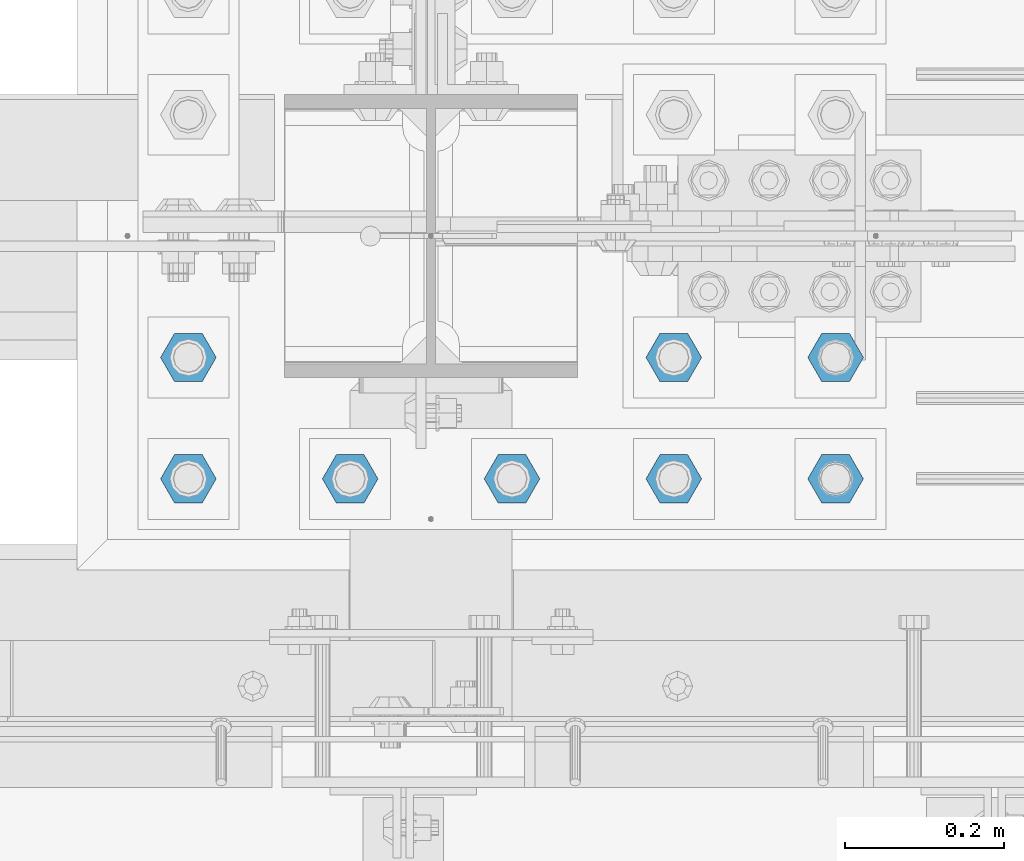
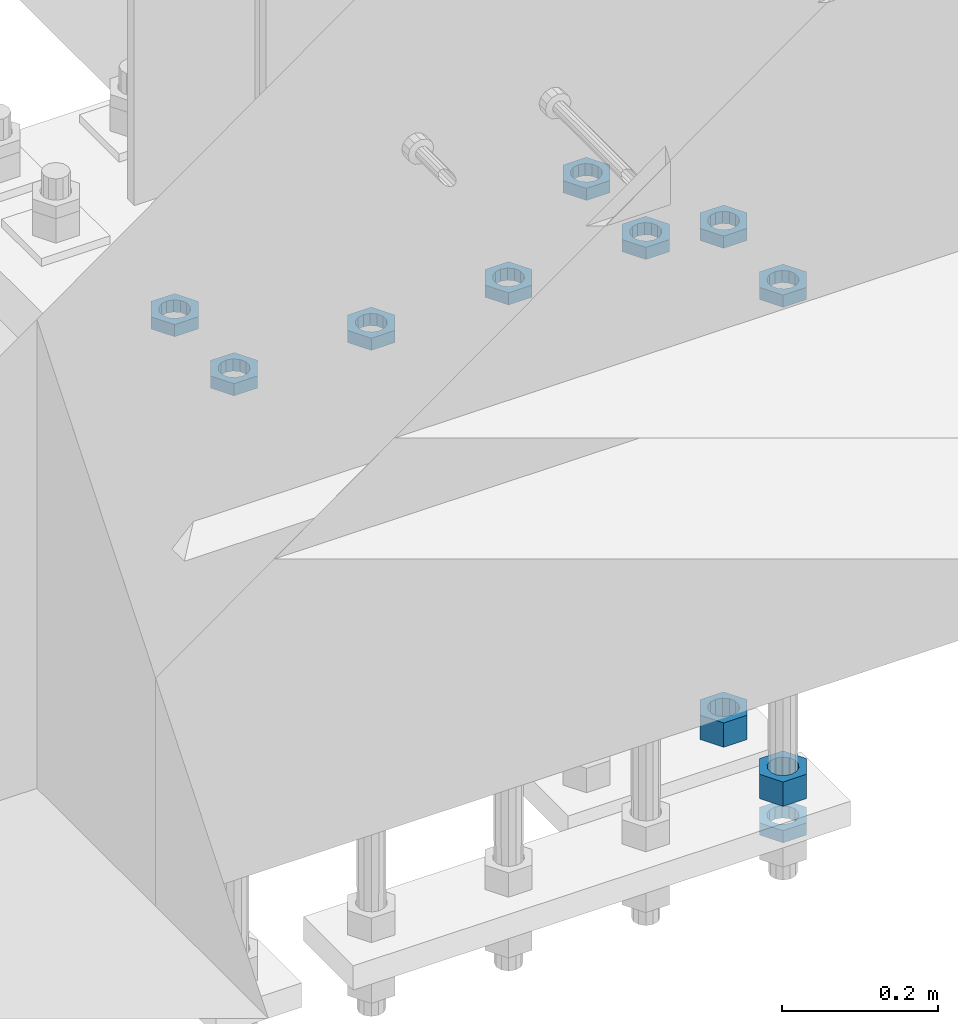
# One storey, part 2791 of 3843: 11 beams, 1 element without a shape of its own.
"""IFC2X3 building model written with IfcOpenShell, lengths in millimetres."""

from ifc_helpers import new_model, si_unit, frame, origin_with_axes, place, context, subcontext, project, spatial, faceted_brep, material, type_object, element, aggregate, save


model = new_model("IFC2X3")

# Units and contexts
model_context = context("Model", 3, precision=1e-05, world=origin_with_axes())
body_context = subcontext(model_context, "Body", "Model", "MODEL_VIEW")
ifc_project = project(units=[si_unit("LENGTHUNIT", "METRE", prefix="MILLI"), si_unit("AREAUNIT", "SQUARE_METRE"), si_unit("VOLUMEUNIT", "CUBIC_METRE"), si_unit("MASSUNIT", "GRAM", prefix="KILO"), si_unit("TIMEUNIT", "SECOND"), si_unit("PLANEANGLEUNIT", "RADIAN"), si_unit("SOLIDANGLEUNIT", "STERADIAN"), si_unit("THERMODYNAMICTEMPERATUREUNIT", "DEGREE_CELSIUS"), si_unit("LUMINOUSINTENSITYUNIT", "LUMEN")], contexts=[model_context])

# Site, building, storey
site_placement = place(None, origin_with_axes())
site = spatial("IfcSite", under=ifc_project, at=site_placement, CompositionType="ELEMENT")
building_placement = place(site_placement, origin_with_axes())
building = spatial("IfcBuilding", under=site, at=building_placement, Name="Undefined", CompositionType="ELEMENT")
storey_placement = place(building_placement, origin_with_axes())
storey = spatial("IfcBuildingStorey", under=building, at=storey_placement, Name="Undefined", CompositionType="ELEMENT", Elevation=0.0)

# Assembly, beams
assembly_placement = place(storey_placement, origin_with_axes())
assembly = element("IfcElementAssembly", 1, at=assembly_placement, inside=storey, Name="TEMPLATE", AssemblyPlace="NOTDEFINED", PredefinedType="RIGID_FRAME")
ifc_material = material(Name="STEEL/A572-50")
beam_type_1 = type_object("IfcBeamType", Name="1-1/2_HEAVY_HEX_NUT", PredefinedType="NOTDEFINED")
beam_1_placement = place(assembly_placement, frame((42570.4, 25463.5, 28841.7000015259), z_axis=(0.0, 1.0, 0.0), x_axis=(0.0, 0.0, -1.0)))
beam_1 = element("IfcBeam", 2, at=beam_1_placement, type_object=beam_type_1, material=ifc_material, Name="NUT", ObjectType="1-1/2_HEAVY_HEX_NUT", context=body_context, shape_type="Brep", body=[
    faceted_brep([(0.0, -34.9199981689453, 0.0), (0.0, -17.4599990844727, -30.25), (38.0999999999985, -17.4599990844727, -30.25), (38.0999999999985, -34.9199981689453, 0.0), (0.0, 17.4599990844727, -30.25), (38.0999999999985, 17.4599990844727, -30.25), (0.0, 34.9199981689453, 0.0), (38.0999999999985, 34.9199981689453, 0.0), (0.0, 17.4599990844727, 30.25), (38.0999999999985, 17.4599990844727, 30.25), (0.0, -17.4599990844727, 30.25), (38.0999999999985, -17.4599990844727, 30.25), (0.0, 0.0, 20.6399993896484), (0.0, 8.9553601105581, 18.5959968835959), (38.0999999999985, 8.9553601105581, 18.5959968835959), (38.0999999999985, 0.0, 20.6399993896484), (0.0, 16.1370013209525, 12.8688291298167), (38.0999999999985, 16.1370013209525, 12.8688291298167), (0.0, 20.1225115123816, 4.59283194104501), (38.0999999999985, 20.1225115123816, 4.59283194104501), (0.0, 20.1225115123816, -4.59283194104501), (38.0999999999985, 20.1225115123816, -4.59283194104501), (0.0, 16.1370013209525, -12.8688291298167), (38.0999999999985, 16.1370013209525, -12.8688291298167), (0.0, 8.9553601105581, -18.5959968835959), (38.0999999999985, 8.9553601105581, -18.5959968835959), (0.0, 0.0, -20.6399993896484), (38.0999999999985, 0.0, -20.6399993896484), (0.0, -8.9553601105581, -18.5959968835959), (38.0999999999985, -8.9553601105581, -18.5959968835959), (0.0, -16.1370013209525, -12.8688291298167), (38.0999999999985, -16.1370013209525, -12.8688291298167), (0.0, -20.1225115123816, -4.59283194104501), (38.0999999999985, -20.1225115123816, -4.59283194104501), (0.0, -20.1225115123816, 4.59283194104501), (38.0999999999985, -20.1225115123816, 4.59283194104501), (0.0, -16.1370013209525, 12.8688291298167), (38.0999999999985, -16.1370013209525, 12.8688291298167), (0.0, -8.9553601105581, 18.5959968835959), (38.0999999999985, -8.9553601105581, 18.5959968835959)], [[[0, 1, 2, 3]], [[1, 4, 5, 2]], [[4, 6, 7, 5]], [[6, 8, 9, 7]], [[8, 10, 11, 9]], [[10, 0, 3, 11]], [[12, 13, 14, 15]], [[13, 16, 17, 14]], [[16, 18, 19, 17]], [[18, 20, 21, 19]], [[20, 22, 23, 21]], [[22, 24, 25, 23]], [[24, 26, 27, 25]], [[26, 28, 29, 27]], [[28, 30, 31, 29]], [[30, 32, 33, 31]], [[32, 34, 35, 33]], [[34, 36, 37, 35]], [[36, 38, 39, 37]], [[38, 12, 15, 39]], [[5, 7, 9, 11, 3, 2], [17, 19, 21, 23, 25, 27, 29, 31, 33, 35, 37, 39, 15, 14]], [[10, 8, 6, 4, 1, 0], [38, 36, 34, 32, 30, 28, 26, 24, 22, 20, 18, 16, 13, 12]]]),
])
beam_2_placement = place(assembly_placement, frame((42570.4, 25311.1, 28841.7000015259), z_axis=(0.0, 1.0, 0.0), x_axis=(0.0, 0.0, -1.0)))
beam_2 = element("IfcBeam", 3, at=beam_2_placement, type_object=beam_type_1, material=ifc_material, Name="NUT", ObjectType="1-1/2_HEAVY_HEX_NUT", context=body_context, shape_type="Brep", body=[
    faceted_brep([(0.0, -34.9199981689453, 0.0), (0.0, -17.4599990844727, -30.25), (38.0999999999985, -17.4599990844727, -30.25), (38.0999999999985, -34.9199981689453, 0.0), (0.0, 17.4599990844727, -30.25), (38.0999999999985, 17.4599990844727, -30.25), (0.0, 34.9199981689453, 0.0), (38.0999999999985, 34.9199981689453, 0.0), (0.0, 17.4599990844727, 30.25), (38.0999999999985, 17.4599990844727, 30.25), (0.0, -17.4599990844727, 30.25), (38.0999999999985, -17.4599990844727, 30.25), (0.0, 0.0, 20.6399993896484), (0.0, 8.9553601105581, 18.5959968835959), (38.0999999999985, 8.9553601105581, 18.5959968835959), (38.0999999999985, 0.0, 20.6399993896484), (0.0, 16.1370013209525, 12.8688291298167), (38.0999999999985, 16.1370013209525, 12.8688291298167), (0.0, 20.1225115123816, 4.59283194104501), (38.0999999999985, 20.1225115123816, 4.59283194104501), (0.0, 20.1225115123816, -4.59283194104501), (38.0999999999985, 20.1225115123816, -4.59283194104501), (0.0, 16.1370013209525, -12.8688291298167), (38.0999999999985, 16.1370013209525, -12.8688291298167), (0.0, 8.9553601105581, -18.5959968835959), (38.0999999999985, 8.9553601105581, -18.5959968835959), (0.0, 0.0, -20.6399993896484), (38.0999999999985, 0.0, -20.6399993896484), (0.0, -8.9553601105581, -18.5959968835959), (38.0999999999985, -8.9553601105581, -18.5959968835959), (0.0, -16.1370013209525, -12.8688291298167), (38.0999999999985, -16.1370013209525, -12.8688291298167), (0.0, -20.1225115123816, -4.59283194104501), (38.0999999999985, -20.1225115123816, -4.59283194104501), (0.0, -20.1225115123816, 4.59283194104501), (38.0999999999985, -20.1225115123816, 4.59283194104501), (0.0, -16.1370013209525, 12.8688291298167), (38.0999999999985, -16.1370013209525, 12.8688291298167), (0.0, -8.9553601105581, 18.5959968835959), (38.0999999999985, -8.9553601105581, 18.5959968835959)], [[[0, 1, 2, 3]], [[1, 4, 5, 2]], [[4, 6, 7, 5]], [[6, 8, 9, 7]], [[8, 10, 11, 9]], [[10, 0, 3, 11]], [[12, 13, 14, 15]], [[13, 16, 17, 14]], [[16, 18, 19, 17]], [[18, 20, 21, 19]], [[20, 22, 23, 21]], [[22, 24, 25, 23]], [[24, 26, 27, 25]], [[26, 28, 29, 27]], [[28, 30, 31, 29]], [[30, 32, 33, 31]], [[32, 34, 35, 33]], [[34, 36, 37, 35]], [[36, 38, 39, 37]], [[38, 12, 15, 39]], [[5, 7, 9, 11, 3, 2], [17, 19, 21, 23, 25, 27, 29, 31, 33, 35, 37, 39, 15, 14]], [[10, 8, 6, 4, 1, 0], [38, 36, 34, 32, 30, 28, 26, 24, 22, 20, 18, 16, 13, 12]]]),
])
beam_type_2 = type_object("IfcBeamType", Name="1-1/2_HALF_NUT", PredefinedType="NOTDEFINED")
beam_3_placement = place(assembly_placement, frame((42570.4, 25463.5, 29603.7), z_axis=(0.0, 1.0, 0.0), x_axis=(0.0, 0.0, -1.0)))
beam_3 = element("IfcBeam", 4, at=beam_3_placement, type_object=beam_type_2, material=ifc_material, Name="NUT", ObjectType="1-1/2_HALF_NUT", context=body_context, shape_type="Brep", body=[
    faceted_brep([(0.0, -34.9199981689453, 0.0), (0.0, -17.4599990844727, -30.25), (19.0500000000029, -17.4599990844727, -30.25), (19.0500000000029, -34.9199981689453, 0.0), (0.0, 17.4599990844727, -30.25), (19.0500000000029, 17.4599990844727, -30.25), (0.0, 34.9199981689453, 0.0), (19.0500000000029, 34.9199981689453, 0.0), (0.0, 17.4599990844727, 30.25), (19.0500000000029, 17.4599990844727, 30.25), (0.0, -17.4599990844727, 30.25), (19.0500000000029, -17.4599990844727, 30.25), (0.0, 0.0, 20.6399993896484), (0.0, 8.9553601105581, 18.5959968835959), (19.0500000000029, 8.95536011056538, 18.5959968835959), (19.0500000000029, 0.0, 20.6399993896484), (0.0, 16.1370013209525, 12.8688291298167), (19.0500000000029, 16.1370013209489, 12.8688291298167), (0.0, 20.1225115123816, 4.59283194104501), (19.0500000000029, 20.1225115123852, 4.59283194104501), (0.0, 20.1225115123816, -4.59283194104501), (19.0500000000029, 20.1225115123852, -4.59283194104501), (0.0, 16.1370013209525, -12.8688291298167), (19.0500000000029, 16.1370013209489, -12.8688291298167), (0.0, 8.9553601105581, -18.5959968835959), (19.0500000000029, 8.95536011056538, -18.5959968835959), (0.0, 0.0, -20.6399993896484), (19.0500000000029, 0.0, -20.6399993896484), (0.0, -8.9553601105581, -18.5959968835959), (19.0500000000029, -8.95536011056538, -18.5959968835959), (0.0, -16.1370013209525, -12.8688291298167), (19.0500000000029, -16.1370013209489, -12.8688291298167), (0.0, -20.1225115123816, -4.59283194104501), (19.0500000000029, -20.1225115123852, -4.59283194104501), (0.0, -20.1225115123816, 4.59283194104501), (19.0500000000029, -20.1225115123852, 4.59283194104501), (0.0, -16.1370013209525, 12.8688291298167), (19.0500000000029, -16.1370013209489, 12.8688291298167), (0.0, -8.9553601105581, 18.5959968835959), (19.0500000000029, -8.95536011056538, 18.5959968835959)], [[[0, 1, 2, 3]], [[1, 4, 5, 2]], [[4, 6, 7, 5]], [[6, 8, 9, 7]], [[8, 10, 11, 9]], [[10, 0, 3, 11]], [[12, 13, 14, 15]], [[13, 16, 17, 14]], [[16, 18, 19, 17]], [[18, 20, 21, 19]], [[20, 22, 23, 21]], [[22, 24, 25, 23]], [[24, 26, 27, 25]], [[26, 28, 29, 27]], [[28, 30, 31, 29]], [[30, 32, 33, 31]], [[32, 34, 35, 33]], [[34, 36, 37, 35]], [[36, 38, 39, 37]], [[38, 12, 15, 39]], [[5, 7, 9, 11, 3, 2], [17, 19, 21, 23, 25, 27, 29, 31, 33, 35, 37, 39, 15, 14]], [[10, 8, 6, 4, 1, 0], [38, 36, 34, 32, 30, 28, 26, 24, 22, 20, 18, 16, 13, 12]]]),
])
beam_4_placement = place(assembly_placement, frame((42570.4, 25311.1, 29603.7), z_axis=(0.0, 1.0, 0.0), x_axis=(0.0, 0.0, -1.0)))
beam_4 = element("IfcBeam", 5, at=beam_4_placement, type_object=beam_type_2, material=ifc_material, Name="NUT", ObjectType="1-1/2_HALF_NUT", context=body_context, shape_type="Brep", body=[
    faceted_brep([(0.0, -34.9199981689453, 0.0), (0.0, -17.4599990844727, -30.25), (19.0500000000029, -17.4599990844727, -30.25), (19.0500000000029, -34.9199981689453, 0.0), (0.0, 17.4599990844727, -30.25), (19.0500000000029, 17.4599990844727, -30.25), (0.0, 34.9199981689453, 0.0), (19.0500000000029, 34.9199981689453, 0.0), (0.0, 17.4599990844727, 30.25), (19.0500000000029, 17.4599990844727, 30.25), (0.0, -17.4599990844727, 30.25), (19.0500000000029, -17.4599990844727, 30.25), (0.0, 0.0, 20.6399993896484), (0.0, 8.9553601105581, 18.5959968835959), (19.0500000000029, 8.95536011056538, 18.5959968835959), (19.0500000000029, 0.0, 20.6399993896484), (0.0, 16.1370013209525, 12.8688291298167), (19.0500000000029, 16.1370013209489, 12.8688291298167), (0.0, 20.1225115123816, 4.59283194104501), (19.0500000000029, 20.1225115123852, 4.59283194104501), (0.0, 20.1225115123816, -4.59283194104501), (19.0500000000029, 20.1225115123852, -4.59283194104501), (0.0, 16.1370013209525, -12.8688291298167), (19.0500000000029, 16.1370013209489, -12.8688291298167), (0.0, 8.9553601105581, -18.5959968835959), (19.0500000000029, 8.95536011056538, -18.5959968835959), (0.0, 0.0, -20.6399993896484), (19.0500000000029, 0.0, -20.6399993896484), (0.0, -8.9553601105581, -18.5959968835959), (19.0500000000029, -8.95536011056538, -18.5959968835959), (0.0, -16.1370013209525, -12.8688291298167), (19.0500000000029, -16.1370013209489, -12.8688291298167), (0.0, -20.1225115123816, -4.59283194104501), (19.0500000000029, -20.1225115123852, -4.59283194104501), (0.0, -20.1225115123816, 4.59283194104501), (19.0500000000029, -20.1225115123852, 4.59283194104501), (0.0, -16.1370013209525, 12.8688291298167), (19.0500000000029, -16.1370013209489, 12.8688291298167), (0.0, -8.9553601105581, 18.5959968835959), (19.0500000000029, -8.95536011056538, 18.5959968835959)], [[[0, 1, 2, 3]], [[1, 4, 5, 2]], [[4, 6, 7, 5]], [[6, 8, 9, 7]], [[8, 10, 11, 9]], [[10, 0, 3, 11]], [[12, 13, 14, 15]], [[13, 16, 17, 14]], [[16, 18, 19, 17]], [[18, 20, 21, 19]], [[20, 22, 23, 21]], [[22, 24, 25, 23]], [[24, 26, 27, 25]], [[26, 28, 29, 27]], [[28, 30, 31, 29]], [[30, 32, 33, 31]], [[32, 34, 35, 33]], [[34, 36, 37, 35]], [[36, 38, 39, 37]], [[38, 12, 15, 39]], [[5, 7, 9, 11, 3, 2], [17, 19, 21, 23, 25, 27, 29, 31, 33, 35, 37, 39, 15, 14]], [[10, 8, 6, 4, 1, 0], [38, 36, 34, 32, 30, 28, 26, 24, 22, 20, 18, 16, 13, 12]]]),
])
beam_5_placement = place(assembly_placement, frame((42570.4, 25311.1, 28765.5000015259), z_axis=(0.0, 1.0, 0.0), x_axis=(0.0, 0.0, -1.0)))
beam_5 = element("IfcBeam", 6, at=beam_5_placement, type_object=beam_type_2, material=ifc_material, Name="NUT", ObjectType="1-1/2_HALF_NUT", context=body_context, shape_type="Brep", body=[
    faceted_brep([(0.0, -34.9199981689453, 0.0), (0.0, -17.4599990844727, -30.25), (19.0500000000029, -17.4599990844727, -30.25), (19.0500000000029, -34.9199981689453, 0.0), (0.0, 17.4599990844727, -30.25), (19.0500000000029, 17.4599990844727, -30.25), (0.0, 34.9199981689453, 0.0), (19.0500000000029, 34.9199981689453, 0.0), (0.0, 17.4599990844727, 30.25), (19.0500000000029, 17.4599990844727, 30.25), (0.0, -17.4599990844727, 30.25), (19.0500000000029, -17.4599990844727, 30.25), (0.0, 0.0, 20.6399993896484), (0.0, 8.9553601105581, 18.5959968835959), (19.0500000000029, 8.95536011056538, 18.5959968835959), (19.0500000000029, 0.0, 20.6399993896484), (0.0, 16.1370013209525, 12.8688291298167), (19.0500000000029, 16.1370013209489, 12.8688291298167), (0.0, 20.1225115123816, 4.59283194104501), (19.0500000000029, 20.1225115123852, 4.59283194104501), (0.0, 20.1225115123816, -4.59283194104501), (19.0500000000029, 20.1225115123852, -4.59283194104501), (0.0, 16.1370013209525, -12.8688291298167), (19.0500000000029, 16.1370013209489, -12.8688291298167), (0.0, 8.9553601105581, -18.5959968835959), (19.0500000000029, 8.95536011056538, -18.5959968835959), (0.0, 0.0, -20.6399993896484), (19.0500000000029, 0.0, -20.6399993896484), (0.0, -8.9553601105581, -18.5959968835959), (19.0500000000029, -8.95536011056538, -18.5959968835959), (0.0, -16.1370013209525, -12.8688291298167), (19.0500000000029, -16.1370013209489, -12.8688291298167), (0.0, -20.1225115123816, -4.59283194104501), (19.0500000000029, -20.1225115123852, -4.59283194104501), (0.0, -20.1225115123816, 4.59283194104501), (19.0500000000029, -20.1225115123852, 4.59283194104501), (0.0, -16.1370013209525, 12.8688291298167), (19.0500000000029, -16.1370013209489, 12.8688291298167), (0.0, -8.9553601105581, 18.5959968835959), (19.0500000000029, -8.95536011056538, 18.5959968835959)], [[[0, 1, 2, 3]], [[1, 4, 5, 2]], [[4, 6, 7, 5]], [[6, 8, 9, 7]], [[8, 10, 11, 9]], [[10, 0, 3, 11]], [[12, 13, 14, 15]], [[13, 16, 17, 14]], [[16, 18, 19, 17]], [[18, 20, 21, 19]], [[20, 22, 23, 21]], [[22, 24, 25, 23]], [[24, 26, 27, 25]], [[26, 28, 29, 27]], [[28, 30, 31, 29]], [[30, 32, 33, 31]], [[32, 34, 35, 33]], [[34, 36, 37, 35]], [[36, 38, 39, 37]], [[38, 12, 15, 39]], [[5, 7, 9, 11, 3, 2], [17, 19, 21, 23, 25, 27, 29, 31, 33, 35, 37, 39, 15, 14]], [[10, 8, 6, 4, 1, 0], [38, 36, 34, 32, 30, 28, 26, 24, 22, 20, 18, 16, 13, 12]]]),
])
beam_6_placement = place(assembly_placement, frame((41757.6, 25311.1, 29749.75), z_axis=(0.0, -1.0, 0.0), x_axis=(0.0, 0.0, -1.0)))
beam_6 = element("IfcBeam", 7, at=beam_6_placement, type_object=beam_type_2, material=ifc_material, Name="NUT", ObjectType="1-1/2_HALF_NUT", context=body_context, shape_type="Brep", body=[
    faceted_brep([(0.0, -34.9199981689453, 0.0), (0.0, -17.4599990844727, -30.25), (19.0500000000029, -17.4599990844727, -30.25), (19.0500000000029, -34.9199981689453, 0.0), (0.0, 17.4599990844727, -30.25), (19.0500000000029, 17.4599990844727, -30.25), (0.0, 34.9199981689453, 0.0), (19.0500000000029, 34.9199981689453, 0.0), (0.0, 17.4599990844727, 30.25), (19.0500000000029, 17.4599990844727, 30.25), (0.0, -17.4599990844727, 30.25), (19.0500000000029, -17.4599990844727, 30.25), (0.0, 0.0, 20.6399993896484), (0.0, 8.9553601105581, 18.5959968835959), (19.0500000000029, 8.95536011056538, 18.5959968835959), (19.0500000000029, 0.0, 20.6399993896484), (0.0, 16.1370013209525, 12.8688291298167), (19.0500000000029, 16.1370013209489, 12.8688291298167), (0.0, 20.1225115123816, 4.59283194104501), (19.0500000000029, 20.1225115123852, 4.59283194104501), (0.0, 20.1225115123816, -4.59283194104501), (19.0500000000029, 20.1225115123852, -4.59283194104501), (0.0, 16.1370013209525, -12.8688291298167), (19.0500000000029, 16.1370013209489, -12.8688291298167), (0.0, 8.9553601105581, -18.5959968835959), (19.0500000000029, 8.95536011056538, -18.5959968835959), (0.0, 0.0, -20.6399993896484), (19.0500000000029, 0.0, -20.6399993896484), (0.0, -8.9553601105581, -18.5959968835959), (19.0500000000029, -8.95536011056538, -18.5959968835959), (0.0, -16.1370013209525, -12.8688291298167), (19.0500000000029, -16.1370013209489, -12.8688291298167), (0.0, -20.1225115123816, -4.59283194104501), (19.0500000000029, -20.1225115123852, -4.59283194104501), (0.0, -20.1225115123816, 4.59283194104501), (19.0500000000029, -20.1225115123852, 4.59283194104501), (0.0, -16.1370013209525, 12.8688291298167), (19.0500000000029, -16.1370013209489, 12.8688291298167), (0.0, -8.9553601105581, 18.5959968835959), (19.0500000000029, -8.95536011056538, 18.5959968835959)], [[[0, 1, 2, 3]], [[1, 4, 5, 2]], [[4, 6, 7, 5]], [[6, 8, 9, 7]], [[8, 10, 11, 9]], [[10, 0, 3, 11]], [[12, 13, 14, 15]], [[13, 16, 17, 14]], [[16, 18, 19, 17]], [[18, 20, 21, 19]], [[20, 22, 23, 21]], [[22, 24, 25, 23]], [[24, 26, 27, 25]], [[26, 28, 29, 27]], [[28, 30, 31, 29]], [[30, 32, 33, 31]], [[32, 34, 35, 33]], [[34, 36, 37, 35]], [[36, 38, 39, 37]], [[38, 12, 15, 39]], [[5, 7, 9, 11, 3, 2], [17, 19, 21, 23, 25, 27, 29, 31, 33, 35, 37, 39, 15, 14]], [[10, 8, 6, 4, 1, 0], [38, 36, 34, 32, 30, 28, 26, 24, 22, 20, 18, 16, 13, 12]]]),
])
beam_7_placement = place(assembly_placement, frame((41960.8, 25311.1, 29749.75), z_axis=(0.0, -1.0, 0.0), x_axis=(0.0, 0.0, -1.0)))
beam_7 = element("IfcBeam", 8, at=beam_7_placement, type_object=beam_type_2, material=ifc_material, Name="NUT", ObjectType="1-1/2_HALF_NUT", context=body_context, shape_type="Brep", body=[
    faceted_brep([(0.0, -34.9199981689453, 0.0), (0.0, -17.4599990844727, -30.25), (19.0500000000029, -17.4599990844727, -30.25), (19.0500000000029, -34.9199981689453, 0.0), (0.0, 17.4599990844727, -30.25), (19.0500000000029, 17.4599990844727, -30.25), (0.0, 34.9199981689453, 0.0), (19.0500000000029, 34.9199981689453, 0.0), (0.0, 17.4599990844727, 30.25), (19.0500000000029, 17.4599990844727, 30.25), (0.0, -17.4599990844727, 30.25), (19.0500000000029, -17.4599990844727, 30.25), (0.0, 0.0, 20.6399993896484), (0.0, 8.9553601105581, 18.5959968835959), (19.0500000000029, 8.95536011056538, 18.5959968835959), (19.0500000000029, 0.0, 20.6399993896484), (0.0, 16.1370013209525, 12.8688291298167), (19.0500000000029, 16.1370013209489, 12.8688291298167), (0.0, 20.1225115123816, 4.59283194104501), (19.0500000000029, 20.1225115123852, 4.59283194104501), (0.0, 20.1225115123816, -4.59283194104501), (19.0500000000029, 20.1225115123852, -4.59283194104501), (0.0, 16.1370013209525, -12.8688291298167), (19.0500000000029, 16.1370013209489, -12.8688291298167), (0.0, 8.9553601105581, -18.5959968835959), (19.0500000000029, 8.95536011056538, -18.5959968835959), (0.0, 0.0, -20.6399993896484), (19.0500000000029, 0.0, -20.6399993896484), (0.0, -8.9553601105581, -18.5959968835959), (19.0500000000029, -8.95536011056538, -18.5959968835959), (0.0, -16.1370013209525, -12.8688291298167), (19.0500000000029, -16.1370013209489, -12.8688291298167), (0.0, -20.1225115123816, -4.59283194104501), (19.0500000000029, -20.1225115123852, -4.59283194104501), (0.0, -20.1225115123816, 4.59283194104501), (19.0500000000029, -20.1225115123852, 4.59283194104501), (0.0, -16.1370013209525, 12.8688291298167), (19.0500000000029, -16.1370013209489, 12.8688291298167), (0.0, -8.9553601105581, 18.5959968835959), (19.0500000000029, -8.95536011056538, 18.5959968835959)], [[[0, 1, 2, 3]], [[1, 4, 5, 2]], [[4, 6, 7, 5]], [[6, 8, 9, 7]], [[8, 10, 11, 9]], [[10, 0, 3, 11]], [[12, 13, 14, 15]], [[13, 16, 17, 14]], [[16, 18, 19, 17]], [[18, 20, 21, 19]], [[20, 22, 23, 21]], [[22, 24, 25, 23]], [[24, 26, 27, 25]], [[26, 28, 29, 27]], [[28, 30, 31, 29]], [[30, 32, 33, 31]], [[32, 34, 35, 33]], [[34, 36, 37, 35]], [[36, 38, 39, 37]], [[38, 12, 15, 39]], [[5, 7, 9, 11, 3, 2], [17, 19, 21, 23, 25, 27, 29, 31, 33, 35, 37, 39, 15, 14]], [[10, 8, 6, 4, 1, 0], [38, 36, 34, 32, 30, 28, 26, 24, 22, 20, 18, 16, 13, 12]]]),
])
beam_8_placement = place(assembly_placement, frame((42164.0, 25311.1, 29749.75), z_axis=(0.0, -1.0, 0.0), x_axis=(0.0, 0.0, -1.0)))
beam_8 = element("IfcBeam", 9, at=beam_8_placement, type_object=beam_type_2, material=ifc_material, Name="NUT", ObjectType="1-1/2_HALF_NUT", context=body_context, shape_type="Brep", body=[
    faceted_brep([(0.0, -34.9199981689453, 0.0), (0.0, -17.4599990844727, -30.25), (19.0500000000029, -17.4599990844727, -30.25), (19.0500000000029, -34.9199981689453, 0.0), (0.0, 17.4599990844727, -30.25), (19.0500000000029, 17.4599990844727, -30.25), (0.0, 34.9199981689453, 0.0), (19.0500000000029, 34.9199981689453, 0.0), (0.0, 17.4599990844727, 30.25), (19.0500000000029, 17.4599990844727, 30.25), (0.0, -17.4599990844727, 30.25), (19.0500000000029, -17.4599990844727, 30.25), (0.0, 0.0, 20.6399993896484), (0.0, 8.9553601105581, 18.5959968835959), (19.0500000000029, 8.95536011056538, 18.5959968835959), (19.0500000000029, 0.0, 20.6399993896484), (0.0, 16.1370013209525, 12.8688291298167), (19.0500000000029, 16.1370013209489, 12.8688291298167), (0.0, 20.1225115123816, 4.59283194104501), (19.0500000000029, 20.1225115123852, 4.59283194104501), (0.0, 20.1225115123816, -4.59283194104501), (19.0500000000029, 20.1225115123852, -4.59283194104501), (0.0, 16.1370013209525, -12.8688291298167), (19.0500000000029, 16.1370013209489, -12.8688291298167), (0.0, 8.9553601105581, -18.5959968835959), (19.0500000000029, 8.95536011056538, -18.5959968835959), (0.0, 0.0, -20.6399993896484), (19.0500000000029, 0.0, -20.6399993896484), (0.0, -8.9553601105581, -18.5959968835959), (19.0500000000029, -8.95536011056538, -18.5959968835959), (0.0, -16.1370013209525, -12.8688291298167), (19.0500000000029, -16.1370013209489, -12.8688291298167), (0.0, -20.1225115123816, -4.59283194104501), (19.0500000000029, -20.1225115123852, -4.59283194104501), (0.0, -20.1225115123816, 4.59283194104501), (19.0500000000029, -20.1225115123852, 4.59283194104501), (0.0, -16.1370013209525, 12.8688291298167), (19.0500000000029, -16.1370013209489, 12.8688291298167), (0.0, -8.9553601105581, 18.5959968835959), (19.0500000000029, -8.95536011056538, 18.5959968835959)], [[[0, 1, 2, 3]], [[1, 4, 5, 2]], [[4, 6, 7, 5]], [[6, 8, 9, 7]], [[8, 10, 11, 9]], [[10, 0, 3, 11]], [[12, 13, 14, 15]], [[13, 16, 17, 14]], [[16, 18, 19, 17]], [[18, 20, 21, 19]], [[20, 22, 23, 21]], [[22, 24, 25, 23]], [[24, 26, 27, 25]], [[26, 28, 29, 27]], [[28, 30, 31, 29]], [[30, 32, 33, 31]], [[32, 34, 35, 33]], [[34, 36, 37, 35]], [[36, 38, 39, 37]], [[38, 12, 15, 39]], [[5, 7, 9, 11, 3, 2], [17, 19, 21, 23, 25, 27, 29, 31, 33, 35, 37, 39, 15, 14]], [[10, 8, 6, 4, 1, 0], [38, 36, 34, 32, 30, 28, 26, 24, 22, 20, 18, 16, 13, 12]]]),
])
beam_9_placement = place(assembly_placement, frame((42367.2, 25311.1, 29749.75), z_axis=(0.0, 1.0, 0.0), x_axis=(0.0, 0.0, -1.0)))
beam_9 = element("IfcBeam", 10, at=beam_9_placement, type_object=beam_type_2, material=ifc_material, Name="NUT", ObjectType="1-1/2_HALF_NUT", context=body_context, shape_type="Brep", body=[
    faceted_brep([(0.0, -34.9199981689453, 0.0), (0.0, -17.4599990844727, -30.25), (19.0500000000029, -17.4599990844727, -30.25), (19.0500000000029, -34.9199981689453, 0.0), (0.0, 17.4599990844727, -30.25), (19.0500000000029, 17.4599990844727, -30.25), (0.0, 34.9199981689453, 0.0), (19.0500000000029, 34.9199981689453, 0.0), (0.0, 17.4599990844727, 30.25), (19.0500000000029, 17.4599990844727, 30.25), (0.0, -17.4599990844727, 30.25), (19.0500000000029, -17.4599990844727, 30.25), (0.0, 0.0, 20.6399993896484), (0.0, 8.9553601105581, 18.5959968835959), (19.0500000000029, 8.95536011056538, 18.5959968835959), (19.0500000000029, 0.0, 20.6399993896484), (0.0, 16.1370013209525, 12.8688291298167), (19.0500000000029, 16.1370013209489, 12.8688291298167), (0.0, 20.1225115123816, 4.59283194104501), (19.0500000000029, 20.1225115123852, 4.59283194104501), (0.0, 20.1225115123816, -4.59283194104501), (19.0500000000029, 20.1225115123852, -4.59283194104501), (0.0, 16.1370013209525, -12.8688291298167), (19.0500000000029, 16.1370013209489, -12.8688291298167), (0.0, 8.9553601105581, -18.5959968835959), (19.0500000000029, 8.95536011056538, -18.5959968835959), (0.0, 0.0, -20.6399993896484), (19.0500000000029, 0.0, -20.6399993896484), (0.0, -8.9553601105581, -18.5959968835959), (19.0500000000029, -8.95536011056538, -18.5959968835959), (0.0, -16.1370013209525, -12.8688291298167), (19.0500000000029, -16.1370013209489, -12.8688291298167), (0.0, -20.1225115123816, -4.59283194104501), (19.0500000000029, -20.1225115123852, -4.59283194104501), (0.0, -20.1225115123816, 4.59283194104501), (19.0500000000029, -20.1225115123852, 4.59283194104501), (0.0, -16.1370013209525, 12.8688291298167), (19.0500000000029, -16.1370013209489, 12.8688291298167), (0.0, -8.9553601105581, 18.5959968835959), (19.0500000000029, -8.95536011056538, 18.5959968835959)], [[[0, 1, 2, 3]], [[1, 4, 5, 2]], [[4, 6, 7, 5]], [[6, 8, 9, 7]], [[8, 10, 11, 9]], [[10, 0, 3, 11]], [[12, 13, 14, 15]], [[13, 16, 17, 14]], [[16, 18, 19, 17]], [[18, 20, 21, 19]], [[20, 22, 23, 21]], [[22, 24, 25, 23]], [[24, 26, 27, 25]], [[26, 28, 29, 27]], [[28, 30, 31, 29]], [[30, 32, 33, 31]], [[32, 34, 35, 33]], [[34, 36, 37, 35]], [[36, 38, 39, 37]], [[38, 12, 15, 39]], [[5, 7, 9, 11, 3, 2], [17, 19, 21, 23, 25, 27, 29, 31, 33, 35, 37, 39, 15, 14]], [[10, 8, 6, 4, 1, 0], [38, 36, 34, 32, 30, 28, 26, 24, 22, 20, 18, 16, 13, 12]]]),
])
beam_10_placement = place(assembly_placement, frame((41757.6, 25463.5, 29749.75), z_axis=(0.0, -1.0, 0.0), x_axis=(0.0, 0.0, -1.0)))
beam_10 = element("IfcBeam", 11, at=beam_10_placement, type_object=beam_type_2, material=ifc_material, Name="NUT", ObjectType="1-1/2_HALF_NUT", context=body_context, shape_type="Brep", body=[
    faceted_brep([(0.0, -34.9199981689453, 0.0), (0.0, -17.4599990844727, -30.25), (19.0500000000029, -17.4599990844727, -30.25), (19.0500000000029, -34.9199981689453, 0.0), (0.0, 17.4599990844727, -30.25), (19.0500000000029, 17.4599990844727, -30.25), (0.0, 34.9199981689453, 0.0), (19.0500000000029, 34.9199981689453, 0.0), (0.0, 17.4599990844727, 30.25), (19.0500000000029, 17.4599990844727, 30.25), (0.0, -17.4599990844727, 30.25), (19.0500000000029, -17.4599990844727, 30.25), (0.0, 0.0, 20.6399993896484), (0.0, 8.9553601105581, 18.5959968835959), (19.0500000000029, 8.95536011056538, 18.5959968835959), (19.0500000000029, 0.0, 20.6399993896484), (0.0, 16.1370013209525, 12.8688291298167), (19.0500000000029, 16.1370013209489, 12.8688291298167), (0.0, 20.1225115123816, 4.59283194104501), (19.0500000000029, 20.1225115123852, 4.59283194104501), (0.0, 20.1225115123816, -4.59283194104501), (19.0500000000029, 20.1225115123852, -4.59283194104501), (0.0, 16.1370013209525, -12.8688291298167), (19.0500000000029, 16.1370013209489, -12.8688291298167), (0.0, 8.9553601105581, -18.5959968835959), (19.0500000000029, 8.95536011056538, -18.5959968835959), (0.0, 0.0, -20.6399993896484), (19.0500000000029, 0.0, -20.6399993896484), (0.0, -8.9553601105581, -18.5959968835959), (19.0500000000029, -8.95536011056538, -18.5959968835959), (0.0, -16.1370013209525, -12.8688291298167), (19.0500000000029, -16.1370013209489, -12.8688291298167), (0.0, -20.1225115123816, -4.59283194104501), (19.0500000000029, -20.1225115123852, -4.59283194104501), (0.0, -20.1225115123816, 4.59283194104501), (19.0500000000029, -20.1225115123852, 4.59283194104501), (0.0, -16.1370013209525, 12.8688291298167), (19.0500000000029, -16.1370013209489, 12.8688291298167), (0.0, -8.9553601105581, 18.5959968835959), (19.0500000000029, -8.95536011056538, 18.5959968835959)], [[[0, 1, 2, 3]], [[1, 4, 5, 2]], [[4, 6, 7, 5]], [[6, 8, 9, 7]], [[8, 10, 11, 9]], [[10, 0, 3, 11]], [[12, 13, 14, 15]], [[13, 16, 17, 14]], [[16, 18, 19, 17]], [[18, 20, 21, 19]], [[20, 22, 23, 21]], [[22, 24, 25, 23]], [[24, 26, 27, 25]], [[26, 28, 29, 27]], [[28, 30, 31, 29]], [[30, 32, 33, 31]], [[32, 34, 35, 33]], [[34, 36, 37, 35]], [[36, 38, 39, 37]], [[38, 12, 15, 39]], [[5, 7, 9, 11, 3, 2], [17, 19, 21, 23, 25, 27, 29, 31, 33, 35, 37, 39, 15, 14]], [[10, 8, 6, 4, 1, 0], [38, 36, 34, 32, 30, 28, 26, 24, 22, 20, 18, 16, 13, 12]]]),
])
beam_11_placement = place(assembly_placement, frame((42367.2, 25463.5, 29749.75), z_axis=(0.0, 1.0, 0.0), x_axis=(0.0, 0.0, -1.0)))
beam_11 = element("IfcBeam", 12, at=beam_11_placement, type_object=beam_type_2, material=ifc_material, Name="NUT", ObjectType="1-1/2_HALF_NUT", context=body_context, shape_type="Brep", body=[
    faceted_brep([(0.0, -34.9199981689453, 0.0), (0.0, -17.4599990844727, -30.25), (19.0500000000029, -17.4599990844727, -30.25), (19.0500000000029, -34.9199981689453, 0.0), (0.0, 17.4599990844727, -30.25), (19.0500000000029, 17.4599990844727, -30.25), (0.0, 34.9199981689453, 0.0), (19.0500000000029, 34.9199981689453, 0.0), (0.0, 17.4599990844727, 30.25), (19.0500000000029, 17.4599990844727, 30.25), (0.0, -17.4599990844727, 30.25), (19.0500000000029, -17.4599990844727, 30.25), (0.0, 0.0, 20.6399993896484), (0.0, 8.9553601105581, 18.5959968835959), (19.0500000000029, 8.95536011056538, 18.5959968835959), (19.0500000000029, 0.0, 20.6399993896484), (0.0, 16.1370013209525, 12.8688291298167), (19.0500000000029, 16.1370013209489, 12.8688291298167), (0.0, 20.1225115123816, 4.59283194104501), (19.0500000000029, 20.1225115123852, 4.59283194104501), (0.0, 20.1225115123816, -4.59283194104501), (19.0500000000029, 20.1225115123852, -4.59283194104501), (0.0, 16.1370013209525, -12.8688291298167), (19.0500000000029, 16.1370013209489, -12.8688291298167), (0.0, 8.9553601105581, -18.5959968835959), (19.0500000000029, 8.95536011056538, -18.5959968835959), (0.0, 0.0, -20.6399993896484), (19.0500000000029, 0.0, -20.6399993896484), (0.0, -8.9553601105581, -18.5959968835959), (19.0500000000029, -8.95536011056538, -18.5959968835959), (0.0, -16.1370013209525, -12.8688291298167), (19.0500000000029, -16.1370013209489, -12.8688291298167), (0.0, -20.1225115123816, -4.59283194104501), (19.0500000000029, -20.1225115123852, -4.59283194104501), (0.0, -20.1225115123816, 4.59283194104501), (19.0500000000029, -20.1225115123852, 4.59283194104501), (0.0, -16.1370013209525, 12.8688291298167), (19.0500000000029, -16.1370013209489, 12.8688291298167), (0.0, -8.9553601105581, 18.5959968835959), (19.0500000000029, -8.95536011056538, 18.5959968835959)], [[[0, 1, 2, 3]], [[1, 4, 5, 2]], [[4, 6, 7, 5]], [[6, 8, 9, 7]], [[8, 10, 11, 9]], [[10, 0, 3, 11]], [[12, 13, 14, 15]], [[13, 16, 17, 14]], [[16, 18, 19, 17]], [[18, 20, 21, 19]], [[20, 22, 23, 21]], [[22, 24, 25, 23]], [[24, 26, 27, 25]], [[26, 28, 29, 27]], [[28, 30, 31, 29]], [[30, 32, 33, 31]], [[32, 34, 35, 33]], [[34, 36, 37, 35]], [[36, 38, 39, 37]], [[38, 12, 15, 39]], [[5, 7, 9, 11, 3, 2], [17, 19, 21, 23, 25, 27, 29, 31, 33, 35, 37, 39, 15, 14]], [[10, 8, 6, 4, 1, 0], [38, 36, 34, 32, 30, 28, 26, 24, 22, 20, 18, 16, 13, 12]]]),
])
aggregate(assembly, [beam_1, beam_2, beam_3, beam_4, beam_5, beam_6, beam_7, beam_8, beam_9, beam_10, beam_11])

save(model, "model.ifc")
